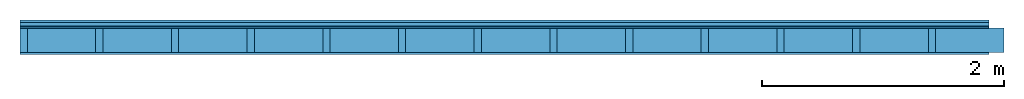
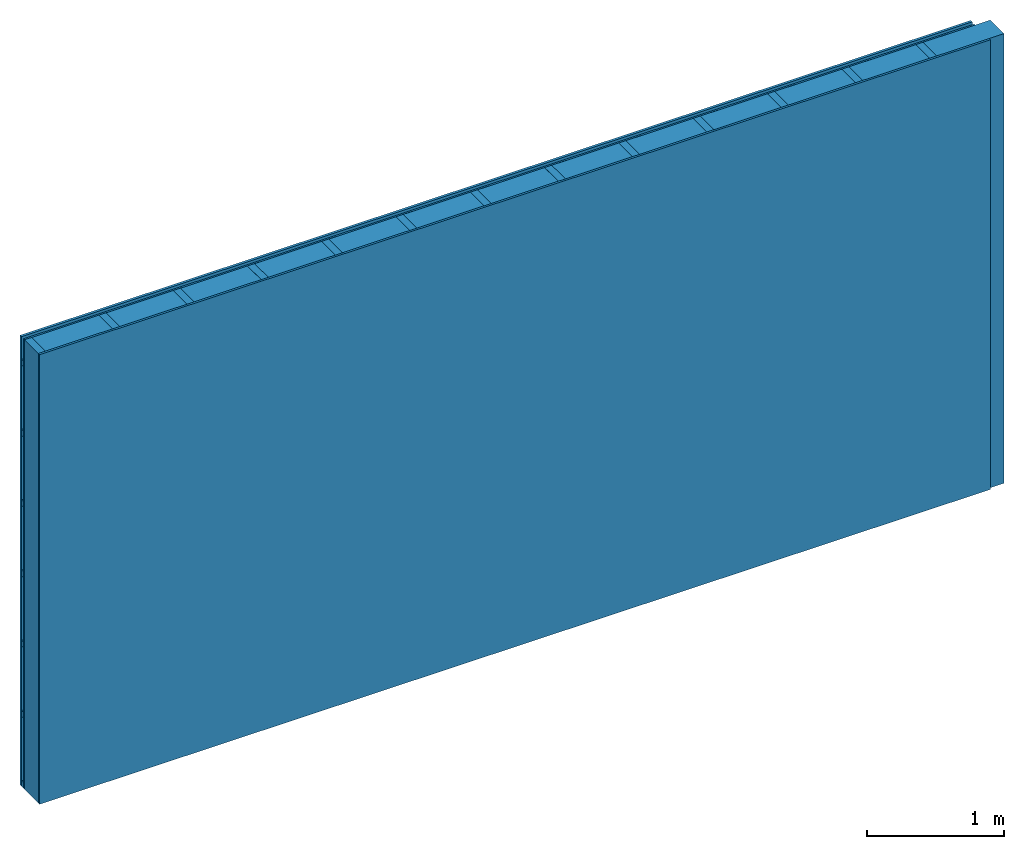
# One storey: 3 members, 3 plates, 1 element without a shape of its own.
"""IFC4 building model written with IfcOpenShell, lengths in metres."""

from ifc_helpers import new_model, si_unit, derived_unit, direction, frame, frame_2d, origin, origin_with_axes, place, context, project, spatial, rectangle, extrude, material, layer, layer_set, type_object, element, aggregate, save


model = new_model("IFC4")

# Units and contexts
plan_context = context("Plan", 3, precision=1e-05, world=origin(), true_north=direction((0.0, 1.0)))
model_context = context("Model", 3, precision=1e-05, world=origin(), true_north=direction((0.0, 1.0)))
ifc_project = project(units=[si_unit("LENGTHUNIT", "METRE"), derived_unit("SOUNDPRESSUREUNIT", [(si_unit("PRESSUREUNIT", "PASCAL", prefix="MICRO"), 0)]), si_unit("ENERGYUNIT", "JOULE", prefix="MEGA"), si_unit("MASSUNIT", "GRAM", prefix="KILO"), derived_unit("THERMALTRANSMITTANCEUNIT", [(si_unit("POWERUNIT", "WATT"), 1), (si_unit("AREAUNIT", "SQUARE_METRE"), -1), (si_unit("THERMODYNAMICTEMPERATUREUNIT", "KELVIN"), -1)]), derived_unit("AREADENSITYUNIT", [(si_unit("MASSUNIT", "GRAM", prefix="KILO"), 1), (si_unit("AREAUNIT", "SQUARE_METRE"), -1)]), derived_unit("USERDEFINED", [(si_unit("ENERGYUNIT", "JOULE", prefix="MEGA"), 1), (si_unit("AREAUNIT", "SQUARE_METRE"), -1)])], contexts=[plan_context, model_context])

# Site, building, storey
site = spatial("IfcSite", under=ifc_project)
building_placement = place(None, origin())
building = spatial("IfcBuilding", under=site, at=building_placement)
storey_placement = place(building_placement, origin())
storey = spatial("IfcBuildingStorey", under=building, at=storey_placement)

# Wall, members, plates
ifc_material_1 = material(Name="Wood cladding horizontal, closed")
ifc_layer_1 = layer(ifc_material_1, 0.022, Name="Cover 1st layer")
ifc_layer_2 = layer(None, 0.03, Name="Battens / profiles (ventilation)")
ifc_material_2 = material(Category="07.013")
ifc_layer_3 = layer(ifc_material_2, 0.015, Name="outside 1st layer")
ifc_material_3 = material(Name="of the art")
ifc_layer_4 = layer(ifc_material_3, 0.0, Name="Bond")
ifc_layer_5 = layer(None, 0.2, Name="Support")
ifc_layer_6 = layer(ifc_material_3, 0.0, Name="Bond")
ifc_layer_7 = layer(ifc_material_2, 0.018, Name="1st layer")
ifc_layer_set = layer_set([ifc_layer_1, ifc_layer_2, ifc_layer_3, ifc_layer_4, ifc_layer_5, ifc_layer_6, ifc_layer_7])
wall_type = type_object("IfcWallType", Name="D0100", PredefinedType="NOTDEFINED", material=ifc_layer_set)
wall_placement = place(None, frame((0.0, 0.0, 0.0), z_axis=(0.0, -1.0, 0.0), x_axis=(1.0, 0.0, 0.0)))
wall = element("IfcWall", 1, at=wall_placement, inside=storey, type_object=wall_type, material=ifc_layer_set, Name="Wall #1")
ifc_material_4 = material()
member_1_placement = place(wall_placement, origin())
member_1 = element("IfcMember", 2, at=member_1_placement, material=ifc_material_4, Name="Battens / profiles (ventilation)", context=plan_context, shape_type="SweptSolid", body=[
    extrude(rectangle(XDim=0.05, YDim=0.03, at=frame_2d((0.025, 0.015), x_axis=(1.0, 0.0))), frame((0.0, 0.0, 0.022), z_axis=(1.0, 0.0, 0.0), x_axis=(0.0, 1.0, 0.0)), (0.0, 0.0, 1.0), 8.0),
    extrude(rectangle(XDim=0.05, YDim=0.03, at=frame_2d((0.025, 0.015), x_axis=(1.0, 0.0))), frame((0.0, 0.625, 0.022), z_axis=(1.0, 0.0, 0.0), x_axis=(0.0, 1.0, 0.0)), (0.0, 0.0, 1.0), 8.0),
    extrude(rectangle(XDim=0.05, YDim=0.03, at=frame_2d((0.025, 0.015), x_axis=(1.0, 0.0))), frame((0.0, 1.25, 0.022), z_axis=(1.0, 0.0, 0.0), x_axis=(0.0, 1.0, 0.0)), (0.0, 0.0, 1.0), 8.0),
    extrude(rectangle(XDim=0.05, YDim=0.03, at=frame_2d((0.025, 0.015), x_axis=(1.0, 0.0))), frame((0.0, 1.875, 0.022), z_axis=(1.0, 0.0, 0.0), x_axis=(0.0, 1.0, 0.0)), (0.0, 0.0, 1.0), 8.0),
    extrude(rectangle(XDim=0.05, YDim=0.03, at=frame_2d((0.025, 0.015), x_axis=(1.0, 0.0))), frame((0.0, 2.5, 0.022), z_axis=(1.0, 0.0, 0.0), x_axis=(0.0, 1.0, 0.0)), (0.0, 0.0, 1.0), 8.0),
    extrude(rectangle(XDim=0.05, YDim=0.03, at=frame_2d((0.025, 0.015), x_axis=(1.0, 0.0))), frame((0.0, 3.125, 0.022), z_axis=(1.0, 0.0, 0.0), x_axis=(0.0, 1.0, 0.0)), (0.0, 0.0, 1.0), 8.0),
    extrude(rectangle(XDim=0.05, YDim=0.03, at=frame_2d((0.025, 0.015), x_axis=(1.0, 0.0))), frame((0.0, 3.75, 0.022), z_axis=(1.0, 0.0, 0.0), x_axis=(0.0, 1.0, 0.0)), (0.0, 0.0, 1.0), 8.0),
])
ifc_material_5 = material()
member_2_placement = place(wall_placement, origin())
member_2 = element("IfcMember", 3, at=member_2_placement, material=ifc_material_5, Name="Support", context=plan_context, shape_type="SweptSolid", body=[
    extrude(rectangle(XDim=0.06, YDim=0.2, at=frame_2d((0.03, 0.1), x_axis=(1.0, 0.0))), frame((0.0, 4.0, 0.067), z_axis=(0.0, -1.0, 0.0), x_axis=(1.0, 0.0, 0.0)), (0.0, 0.0, 1.0), 4.0),
    extrude(rectangle(XDim=0.06, YDim=0.2, at=frame_2d((0.03, 0.1), x_axis=(1.0, 0.0))), frame((0.625, 4.0, 0.067), z_axis=(0.0, -1.0, 0.0), x_axis=(1.0, 0.0, 0.0)), (0.0, 0.0, 1.0), 4.0),
    extrude(rectangle(XDim=0.06, YDim=0.2, at=frame_2d((0.03, 0.1), x_axis=(1.0, 0.0))), frame((1.25, 4.0, 0.067), z_axis=(0.0, -1.0, 0.0), x_axis=(1.0, 0.0, 0.0)), (0.0, 0.0, 1.0), 4.0),
    extrude(rectangle(XDim=0.06, YDim=0.2, at=frame_2d((0.03, 0.1), x_axis=(1.0, 0.0))), frame((1.875, 4.0, 0.067), z_axis=(0.0, -1.0, 0.0), x_axis=(1.0, 0.0, 0.0)), (0.0, 0.0, 1.0), 4.0),
    extrude(rectangle(XDim=0.06, YDim=0.2, at=frame_2d((0.03, 0.1), x_axis=(1.0, 0.0))), frame((2.5, 4.0, 0.067), z_axis=(0.0, -1.0, 0.0), x_axis=(1.0, 0.0, 0.0)), (0.0, 0.0, 1.0), 4.0),
    extrude(rectangle(XDim=0.06, YDim=0.2, at=frame_2d((0.03, 0.1), x_axis=(1.0, 0.0))), frame((3.125, 4.0, 0.067), z_axis=(0.0, -1.0, 0.0), x_axis=(1.0, 0.0, 0.0)), (0.0, 0.0, 1.0), 4.0),
    extrude(rectangle(XDim=0.06, YDim=0.2, at=frame_2d((0.03, 0.1), x_axis=(1.0, 0.0))), frame((3.75, 4.0, 0.067), z_axis=(0.0, -1.0, 0.0), x_axis=(1.0, 0.0, 0.0)), (0.0, 0.0, 1.0), 4.0),
    extrude(rectangle(XDim=0.06, YDim=0.2, at=frame_2d((0.03, 0.1), x_axis=(1.0, 0.0))), frame((4.375, 4.0, 0.067), z_axis=(0.0, -1.0, 0.0), x_axis=(1.0, 0.0, 0.0)), (0.0, 0.0, 1.0), 4.0),
    extrude(rectangle(XDim=0.06, YDim=0.2, at=frame_2d((0.03, 0.1), x_axis=(1.0, 0.0))), frame((5.0, 4.0, 0.067), z_axis=(0.0, -1.0, 0.0), x_axis=(1.0, 0.0, 0.0)), (0.0, 0.0, 1.0), 4.0),
    extrude(rectangle(XDim=0.06, YDim=0.2, at=frame_2d((0.03, 0.1), x_axis=(1.0, 0.0))), frame((5.625, 4.0, 0.067), z_axis=(0.0, -1.0, 0.0), x_axis=(1.0, 0.0, 0.0)), (0.0, 0.0, 1.0), 4.0),
    extrude(rectangle(XDim=0.06, YDim=0.2, at=frame_2d((0.03, 0.1), x_axis=(1.0, 0.0))), frame((6.25, 4.0, 0.067), z_axis=(0.0, -1.0, 0.0), x_axis=(1.0, 0.0, 0.0)), (0.0, 0.0, 1.0), 4.0),
    extrude(rectangle(XDim=0.06, YDim=0.2, at=frame_2d((0.03, 0.1), x_axis=(1.0, 0.0))), frame((6.875, 4.0, 0.067), z_axis=(0.0, -1.0, 0.0), x_axis=(1.0, 0.0, 0.0)), (0.0, 0.0, 1.0), 4.0),
    extrude(rectangle(XDim=0.06, YDim=0.2, at=frame_2d((0.03, 0.1), x_axis=(1.0, 0.0))), frame((7.5, 4.0, 0.067), z_axis=(0.0, -1.0, 0.0), x_axis=(1.0, 0.0, 0.0)), (0.0, 0.0, 1.0), 4.0),
])
ifc_material_6 = material()
member_3_placement = place(wall_placement, origin())
member_3 = element("IfcMember", 4, at=member_3_placement, material=ifc_material_6, Name="Cavity", context=plan_context, shape_type="SweptSolid", body=[
    extrude(rectangle(XDim=0.565, YDim=0.2, at=frame_2d((0.2825, 0.1), x_axis=(1.0, 0.0))), frame((0.06, 4.0, 0.067), z_axis=(0.0, -1.0, 0.0), x_axis=(1.0, 0.0, 0.0)), (0.0, 0.0, 1.0), 4.0),
    extrude(rectangle(XDim=0.565, YDim=0.2, at=frame_2d((0.2825, 0.1), x_axis=(1.0, 0.0))), frame((0.685, 4.0, 0.067), z_axis=(0.0, -1.0, 0.0), x_axis=(1.0, 0.0, 0.0)), (0.0, 0.0, 1.0), 4.0),
    extrude(rectangle(XDim=0.565, YDim=0.2, at=frame_2d((0.2825, 0.1), x_axis=(1.0, 0.0))), frame((1.31, 4.0, 0.067), z_axis=(0.0, -1.0, 0.0), x_axis=(1.0, 0.0, 0.0)), (0.0, 0.0, 1.0), 4.0),
    extrude(rectangle(XDim=0.565, YDim=0.2, at=frame_2d((0.2825, 0.1), x_axis=(1.0, 0.0))), frame((1.935, 4.0, 0.067), z_axis=(0.0, -1.0, 0.0), x_axis=(1.0, 0.0, 0.0)), (0.0, 0.0, 1.0), 4.0),
    extrude(rectangle(XDim=0.565, YDim=0.2, at=frame_2d((0.2825, 0.1), x_axis=(1.0, 0.0))), frame((2.56, 4.0, 0.067), z_axis=(0.0, -1.0, 0.0), x_axis=(1.0, 0.0, 0.0)), (0.0, 0.0, 1.0), 4.0),
    extrude(rectangle(XDim=0.565, YDim=0.2, at=frame_2d((0.2825, 0.1), x_axis=(1.0, 0.0))), frame((3.185, 4.0, 0.067), z_axis=(0.0, -1.0, 0.0), x_axis=(1.0, 0.0, 0.0)), (0.0, 0.0, 1.0), 4.0),
    extrude(rectangle(XDim=0.565, YDim=0.2, at=frame_2d((0.2825, 0.1), x_axis=(1.0, 0.0))), frame((3.81, 4.0, 0.067), z_axis=(0.0, -1.0, 0.0), x_axis=(1.0, 0.0, 0.0)), (0.0, 0.0, 1.0), 4.0),
    extrude(rectangle(XDim=0.565, YDim=0.2, at=frame_2d((0.2825, 0.1), x_axis=(1.0, 0.0))), frame((4.435, 4.0, 0.067), z_axis=(0.0, -1.0, 0.0), x_axis=(1.0, 0.0, 0.0)), (0.0, 0.0, 1.0), 4.0),
    extrude(rectangle(XDim=0.565, YDim=0.2, at=frame_2d((0.2825, 0.1), x_axis=(1.0, 0.0))), frame((5.06, 4.0, 0.067), z_axis=(0.0, -1.0, 0.0), x_axis=(1.0, 0.0, 0.0)), (0.0, 0.0, 1.0), 4.0),
    extrude(rectangle(XDim=0.565, YDim=0.2, at=frame_2d((0.2825, 0.1), x_axis=(1.0, 0.0))), frame((5.685, 4.0, 0.067), z_axis=(0.0, -1.0, 0.0), x_axis=(1.0, 0.0, 0.0)), (0.0, 0.0, 1.0), 4.0),
    extrude(rectangle(XDim=0.565, YDim=0.2, at=frame_2d((0.2825, 0.1), x_axis=(1.0, 0.0))), frame((6.31, 4.0, 0.067), z_axis=(0.0, -1.0, 0.0), x_axis=(1.0, 0.0, 0.0)), (0.0, 0.0, 1.0), 4.0),
    extrude(rectangle(XDim=0.565, YDim=0.2, at=frame_2d((0.2825, 0.1), x_axis=(1.0, 0.0))), frame((6.935, 4.0, 0.067), z_axis=(0.0, -1.0, 0.0), x_axis=(1.0, 0.0, 0.0)), (0.0, 0.0, 1.0), 4.0),
    extrude(rectangle(XDim=0.565, YDim=0.2, at=frame_2d((0.2825, 0.1), x_axis=(1.0, 0.0))), frame((7.56, 4.0, 0.067), z_axis=(0.0, -1.0, 0.0), x_axis=(1.0, 0.0, 0.0)), (0.0, 0.0, 1.0), 4.0),
])
plate_1_placement = place(wall_placement, origin())
plate_1 = element("IfcPlate", 5, at=plate_1_placement, material=ifc_material_1, Name="Cover 1st layer", context=plan_context, shape_type="SweptSolid", body=[
    extrude(rectangle(XDim=8.0, YDim=4.0, at=frame_2d((4.0, 2.0), x_axis=(1.0, 0.0))), origin_with_axes(), (0.0, 0.0, 1.0), 0.022),
])
plate_2_placement = place(wall_placement, origin())
plate_2 = element("IfcPlate", 6, at=plate_2_placement, material=ifc_material_2, Name="outside 1st layer", context=plan_context, shape_type="SweptSolid", body=[
    extrude(rectangle(XDim=8.0, YDim=4.0, at=frame_2d((4.0, 2.0), x_axis=(1.0, 0.0))), frame((0.0, 0.0, 0.052), z_axis=(0.0, 0.0, 1.0), x_axis=(1.0, 0.0, 0.0)), (0.0, 0.0, 1.0), 0.015),
])
plate_3_placement = place(wall_placement, origin())
plate_3 = element("IfcPlate", 7, at=plate_3_placement, material=ifc_material_2, Name="1st layer", context=plan_context, shape_type="SweptSolid", body=[
    extrude(rectangle(XDim=8.0, YDim=4.0, at=frame_2d((4.0, 2.0), x_axis=(1.0, 0.0))), frame((0.0, 0.0, 0.267), z_axis=(0.0, 0.0, 1.0), x_axis=(1.0, 0.0, 0.0)), (0.0, 0.0, 1.0), 0.018),
])
aggregate(wall, [plate_1, member_1, plate_2, member_2, member_3, plate_3])

save(model, "model.ifc")
